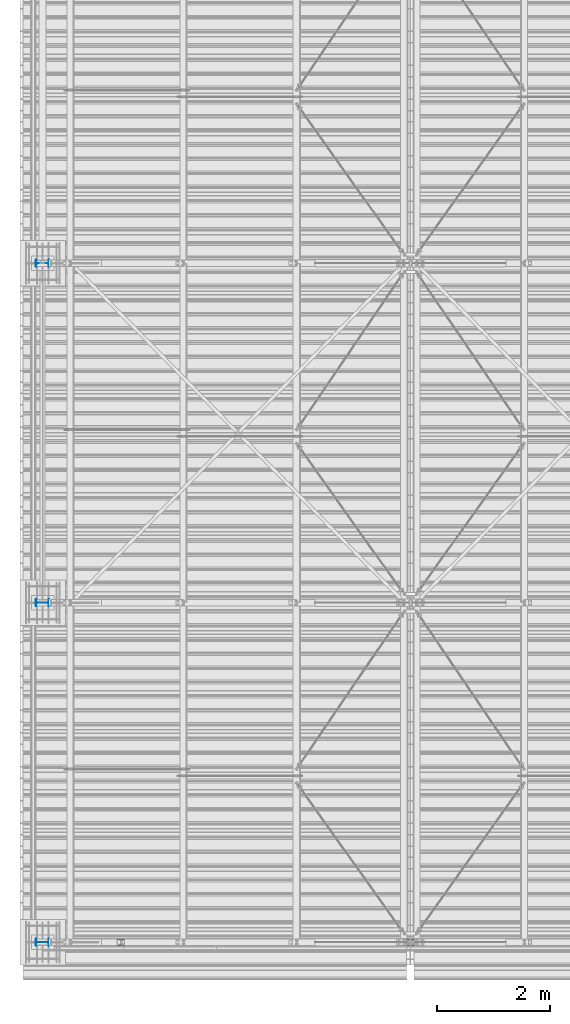
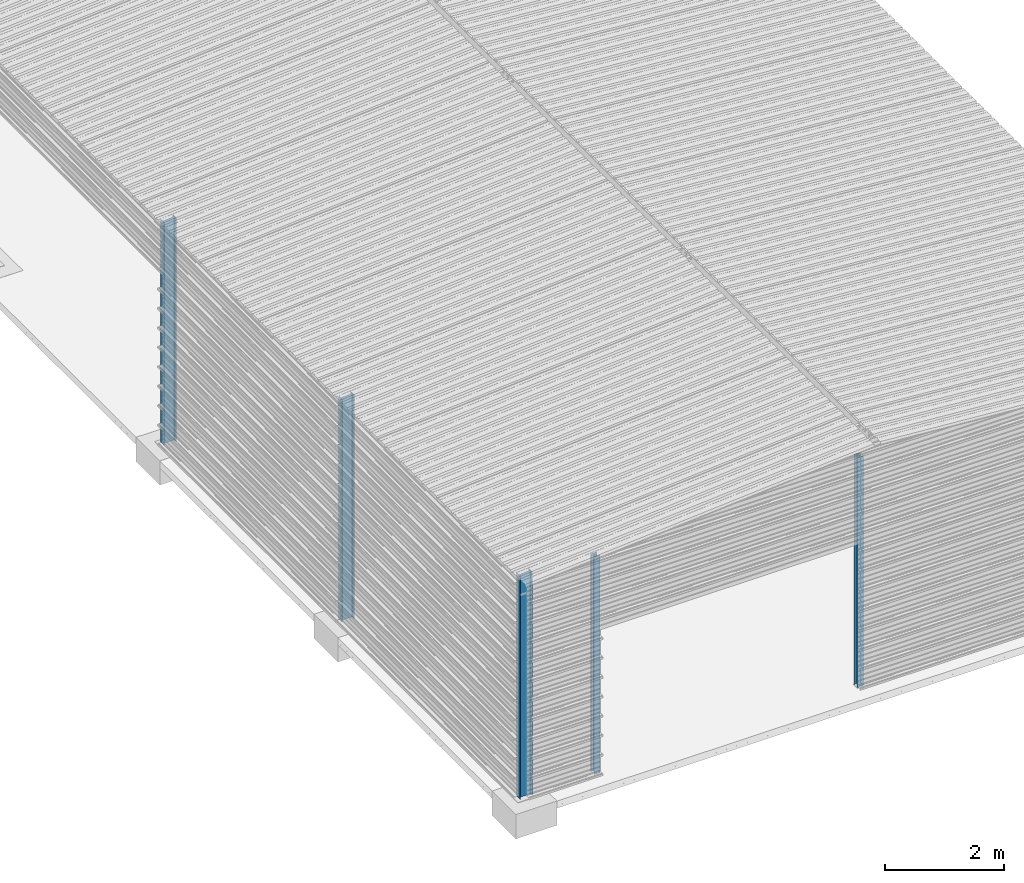
# One storey, part 2 of 70: 5 columns, 5 elements without a shape of their own.
"""IFC2X3 building model written with IfcOpenShell, lengths in millimetres."""

from ifc_helpers import new_model, si_unit, frame, origin_with_axes, origin_2d_with_axis, place, context, subcontext, project, spatial, i_section, extrude, clip, halfspace, material, type_object, element, aggregate, save


model = new_model("IFC2X3")

# Units and contexts
model_context = context("Model", 3, precision=1e-05, world=origin_with_axes())
body_context = subcontext(model_context, "Body", "Model", "MODEL_VIEW")
ifc_project = project(units=[si_unit("LENGTHUNIT", "METRE", prefix="MILLI"), si_unit("AREAUNIT", "SQUARE_METRE"), si_unit("VOLUMEUNIT", "CUBIC_METRE"), si_unit("MASSUNIT", "GRAM", prefix="KILO"), si_unit("TIMEUNIT", "SECOND"), si_unit("PLANEANGLEUNIT", "RADIAN"), si_unit("SOLIDANGLEUNIT", "STERADIAN"), si_unit("THERMODYNAMICTEMPERATUREUNIT", "DEGREE_CELSIUS"), si_unit("LUMINOUSINTENSITYUNIT", "LUMEN")], contexts=[model_context])

# Site, building, storey
site_placement = place(None, origin_with_axes())
site = spatial("IfcSite", under=ifc_project, at=site_placement, CompositionType="ELEMENT")
building_placement = place(site_placement, origin_with_axes())
building = spatial("IfcBuilding", under=site, at=building_placement, Name="Undefined", CompositionType="ELEMENT")
storey_placement = place(building_placement, origin_with_axes())
storey = spatial("IfcBuildingStorey", under=building, at=storey_placement, Name="Undefined", CompositionType="ELEMENT", Elevation=0.0)

# Assembly, column
assembly_1_placement = place(storey_placement, origin_with_axes())
assembly_1 = element("IfcElementAssembly", 1, at=assembly_1_placement, inside=storey, Name="Steel Assembly", AssemblyPlace="NOTDEFINED", PredefinedType="RIGID_FRAME")
ifc_material = material(Name="STEEL/S235JR")
column_type_1 = type_object("IfcColumnType", Name="HEA120", PredefinedType="NOTDEFINED")
column_1_placement = place(assembly_1_placement, frame((1379.0, 0.0, 5.0), z_axis=(0.0, 0.0, 1.0), x_axis=(0.0, 1.0, 0.0)))
column_1 = element("IfcColumn", 2, at=column_1_placement, type_object=column_type_1, material=ifc_material, Name="POTEAU", ObjectType="HEA120", context=body_context, shape_type="Clipping", body=[
    clip(clip(clip(extrude(i_section(OverallWidth=120.0, OverallDepth=114.0, WebThickness=5.0, FlangeThickness=8.0, FilletRadius=12.0, at=origin_2d_with_axis()), frame((0.0, 0.0, 4724.67503646996), z_axis=(0.0, 0.0, -1.0), x_axis=(0.0, 1.0, 0.0)), (0.0, 0.0, 1.0), 4734.31), halfspace(frame((-57.0, 60.0, 4465.78206884498), z_axis=(0.0, 0.0766964990376766, 0.997054485489817), x_axis=(1.0, 0.0, 0.0)), False)), halfspace(frame((-57.0, 60.0, 4475.81161109671), z_axis=(0.0, 0.0766964990376766, 0.997054485489817), x_axis=(1.0, 0.0, 0.0)), False)), halfspace(frame((0.0, 67.6176470682785, -4.97058824662781), z_axis=(0.0, 0.0, -1.0), x_axis=(-1.0, 0.0, 0.0)), False)),
])
aggregate(assembly_1, [column_1])

assembly_2_placement = place(storey_placement, origin_with_axes())
assembly_2 = element("IfcElementAssembly", 3, at=assembly_2_placement, inside=storey, Name="Steel Assembly", AssemblyPlace="NOTDEFINED", PredefinedType="RIGID_FRAME")
column_2_placement = place(assembly_2_placement, frame((6500.0, 0.0, 5.0), z_axis=(0.0, 0.0, 1.0), x_axis=(0.0, 1.0, 0.0)))
column_2 = element("IfcColumn", 4, at=column_2_placement, type_object=column_type_1, material=ifc_material, Name="POTEAU", ObjectType="HEA120", context=body_context, shape_type="Clipping", body=[
    clip(extrude(i_section(OverallWidth=120.0, OverallDepth=114.0, WebThickness=5.0, FlangeThickness=8.0, FilletRadius=12.0, at=origin_2d_with_axis()), frame((0.0, 0.0, 4724.67503646996), z_axis=(0.0, 0.0, -1.0), x_axis=(0.0, 1.0, 0.0)), (0.0, 0.0, 1.0), 4729.65), halfspace(frame((0.0, 67.6176470682785, -4.97058824662781), z_axis=(0.0, 0.0, -1.0), x_axis=(-1.0, 0.0, 0.0)), False)),
])
aggregate(assembly_2, [column_2])

assembly_3_placement = place(storey_placement, origin_with_axes())
assembly_3 = element("IfcElementAssembly", 5, at=assembly_3_placement, inside=storey, Name="Steel Assembly", AssemblyPlace="NOTDEFINED", PredefinedType="RIGID_FRAME")
column_type_2 = type_object("IfcColumnType", Name="IPE240", PredefinedType="NOTDEFINED")
column_3_placement = place(assembly_3_placement, frame((0.0, 12000.0, 0.0), z_axis=(0.0, 0.0, 1.0), x_axis=(1.0, 0.0, 0.0)))
column_3 = element("IfcColumn", 6, at=column_3_placement, type_object=column_type_2, material=ifc_material, Name="POTEAU", ObjectType="IPE240", context=body_context, shape_type="Clipping", body=[
    clip(extrude(i_section(OverallWidth=120.0, OverallDepth=240.0, WebThickness=6.199999809, FlangeThickness=9.800000191, FilletRadius=15.0, at=origin_2d_with_axis()), frame((0.0, 0.0, 4599.29353476665), z_axis=(0.0, 0.0, -1.0), x_axis=(0.0, 1.0, 0.0)), (0.0, 0.0, 1.0), 4599.29), halfspace(frame((170.766964989612, 0.0, 4603.10637823504), z_axis=(-0.0766964990376602, 0.0, 0.997054485489818), x_axis=(0.0, -1.0, 0.0)), False)),
])
aggregate(assembly_3, [column_3])

assembly_4_placement = place(storey_placement, origin_with_axes())
assembly_4 = element("IfcElementAssembly", 7, at=assembly_4_placement, inside=storey, Name="Steel Assembly", AssemblyPlace="NOTDEFINED", PredefinedType="RIGID_FRAME")
column_4_placement = place(assembly_4_placement, frame((0.0, 6000.0, 0.0), z_axis=(0.0, 0.0, 1.0), x_axis=(1.0, 0.0, 0.0)))
column_4 = element("IfcColumn", 8, at=column_4_placement, type_object=column_type_2, material=ifc_material, Name="POTEAU", ObjectType="IPE240", context=body_context, shape_type="Clipping", body=[
    clip(extrude(i_section(OverallWidth=120.0, OverallDepth=240.0, WebThickness=6.199999809, FlangeThickness=9.800000191, FilletRadius=15.0, at=origin_2d_with_axis()), frame((0.0, 0.0, 4599.29353476665), z_axis=(0.0, 0.0, -1.0), x_axis=(0.0, 1.0, 0.0)), (0.0, 0.0, 1.0), 4599.29), halfspace(frame((170.766964989612, 0.0, 4603.10637823504), z_axis=(-0.0766964990376602, 0.0, 0.997054485489818), x_axis=(0.0, -1.0, 0.0)), False)),
])
aggregate(assembly_4, [column_4])

assembly_5_placement = place(storey_placement, origin_with_axes())
assembly_5 = element("IfcElementAssembly", 9, at=assembly_5_placement, inside=storey, Name="Steel Assembly", AssemblyPlace="NOTDEFINED", PredefinedType="RIGID_FRAME")
column_5_placement = place(assembly_5_placement, origin_with_axes())
column_5 = element("IfcColumn", 10, at=column_5_placement, type_object=column_type_2, material=ifc_material, Name="POTEAU", ObjectType="IPE240", context=body_context, shape_type="Clipping", body=[
    clip(extrude(i_section(OverallWidth=120.0, OverallDepth=240.0, WebThickness=6.199999809, FlangeThickness=9.800000191, FilletRadius=15.0, at=origin_2d_with_axis()), frame((0.0, 0.0, 4599.29353476665), z_axis=(0.0, 0.0, -1.0), x_axis=(0.0, 1.0, 0.0)), (0.0, 0.0, 1.0), 4599.29), halfspace(frame((170.766964989612, 0.0, 4603.10637823504), z_axis=(-0.0766964990376602, 0.0, 0.997054485489818), x_axis=(0.0, -1.0, 0.0)), False)),
])
aggregate(assembly_5, [column_5])

save(model, "model.ifc")
